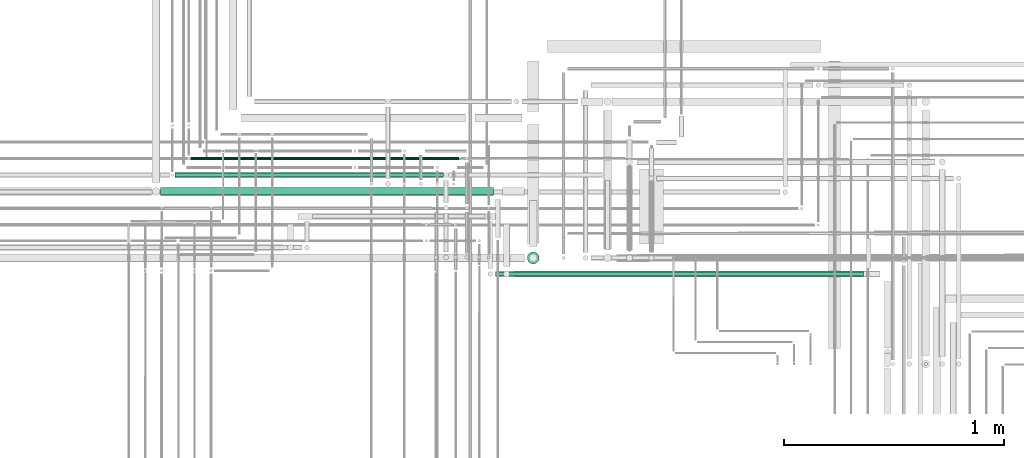
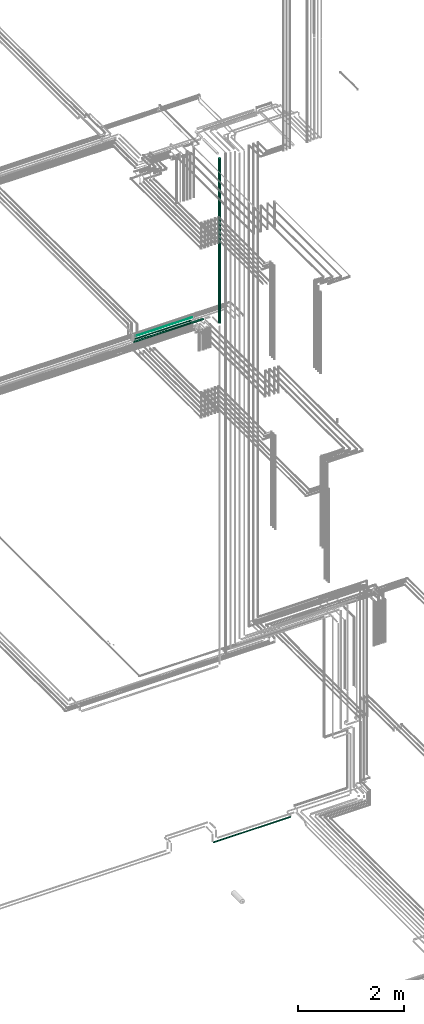
# One storey, part 83 of 331: 5 flow segments.
"""IFC2X3 building model written with IfcOpenShell, lengths in millimetres."""

from ifc_helpers import new_model, entity, si_unit, converted_unit, derived_unit, direction, frame, frame_2d, origin, origin_2d_with_axis, place, context, subcontext, project, spatial, circle, extrude, type_object, element, save


model = new_model("IFC2X3")

# Units and contexts
model_context = context("Model", 3, precision=0.01, world=origin(), true_north=direction((6.12303176911189e-17, 1.0)))
body_context = subcontext(model_context, "Body", "Model", "MODEL_VIEW")
ifc_project = project(units=[si_unit("LENGTHUNIT", "METRE", prefix="MILLI"), si_unit("AREAUNIT", "SQUARE_METRE"), si_unit("VOLUMEUNIT", "CUBIC_METRE"), converted_unit("PLANEANGLEUNIT", "DEGREE", entity("IfcRatioMeasure", 0.0174532925199433), si_unit("PLANEANGLEUNIT", "RADIAN"), dimensions=[0, 0, 0, 0, 0, 0, 0]), si_unit("MASSUNIT", "GRAM", prefix="KILO"), derived_unit("MASSDENSITYUNIT", [(si_unit("MASSUNIT", "GRAM", prefix="KILO"), 1), (si_unit("LENGTHUNIT", "METRE"), -3)]), derived_unit("MOMENTOFINERTIAUNIT", [(si_unit("LENGTHUNIT", "METRE"), 4)]), si_unit("TIMEUNIT", "SECOND"), si_unit("FREQUENCYUNIT", "HERTZ"), si_unit("THERMODYNAMICTEMPERATUREUNIT", "DEGREE_CELSIUS"), derived_unit("THERMALTRANSMITTANCEUNIT", [(si_unit("MASSUNIT", "GRAM", prefix="KILO"), 1), (si_unit("THERMODYNAMICTEMPERATUREUNIT", "KELVIN"), -1), (si_unit("TIMEUNIT", "SECOND"), -3)]), derived_unit("VOLUMETRICFLOWRATEUNIT", [(si_unit("LENGTHUNIT", "METRE"), 3), (si_unit("TIMEUNIT", "SECOND"), -1)]), derived_unit("MASSFLOWRATEUNIT", [(si_unit("MASSUNIT", "GRAM", prefix="KILO"), 1), (si_unit("TIMEUNIT", "SECOND"), -1)]), derived_unit("ROTATIONALFREQUENCYUNIT", [(si_unit("TIMEUNIT", "SECOND"), -1)]), si_unit("ELECTRICCURRENTUNIT", "AMPERE"), si_unit("ELECTRICVOLTAGEUNIT", "VOLT"), si_unit("POWERUNIT", "WATT"), si_unit("FORCEUNIT", "NEWTON", prefix="KILO"), si_unit("ILLUMINANCEUNIT", "LUX"), si_unit("LUMINOUSFLUXUNIT", "LUMEN"), si_unit("LUMINOUSINTENSITYUNIT", "CANDELA"), derived_unit("USERDEFINED", [(si_unit("MASSUNIT", "GRAM", prefix="KILO"), -1), (si_unit("LENGTHUNIT", "METRE"), -2), (si_unit("TIMEUNIT", "SECOND"), 3), (si_unit("LUMINOUSFLUXUNIT", "LUMEN"), 1)]), derived_unit("LINEARVELOCITYUNIT", [(si_unit("LENGTHUNIT", "METRE"), 1), (si_unit("TIMEUNIT", "SECOND"), -1)]), si_unit("PRESSUREUNIT", "PASCAL"), derived_unit("USERDEFINED", [(si_unit("LENGTHUNIT", "METRE"), -2), (si_unit("MASSUNIT", "GRAM", prefix="KILO"), 1), (si_unit("TIMEUNIT", "SECOND"), -2)]), derived_unit("LINEARFORCEUNIT", [(si_unit("MASSUNIT", "GRAM", prefix="KILO"), 1), (si_unit("LENGTHUNIT", "METRE"), 1), (si_unit("TIMEUNIT", "SECOND"), -2), (si_unit("LENGTHUNIT", "METRE"), -1)]), derived_unit("PLANARFORCEUNIT", [(si_unit("MASSUNIT", "GRAM", prefix="KILO"), 1), (si_unit("LENGTHUNIT", "METRE"), 1), (si_unit("TIMEUNIT", "SECOND"), -2), (si_unit("LENGTHUNIT", "METRE"), -2)])], contexts=[model_context])

# Site, building, storey
site_placement = place(None, frame((0.0, -0.00077364408347762, 0.0)))
site = spatial("IfcSite", under=ifc_project, at=site_placement, CompositionType="ELEMENT")
building_placement = place(site_placement, origin())
building = spatial("IfcBuilding", under=site, at=building_placement, CompositionType="ELEMENT")
storey_placement = place(building_placement, origin())
storey = spatial("IfcBuildingStorey", under=building, at=storey_placement, CompositionType="ELEMENT", Elevation=0.0)

# Flow segments
pipe_segment_type = type_object("IfcPipeSegmentType", PredefinedType="NOTDEFINED")
flow_segment_1_placement = place(storey_placement, frame((62152.1085312929, 8593.02529159146, 14542.4047277641)))
element("IfcFlowSegment", 1, at=flow_segment_1_placement, inside=storey, type_object=pipe_segment_type, context=body_context, shape_type="SweptSolid", body=[
    extrude(circle(Radius=6.0, at=frame_2d((-2.16573425859679e-12, -2.16573425859679e-12), x_axis=(1.0, 0.0))), frame((0.0, 7.59527223591778, 7.59527223591887), z_axis=(1.0, 0.0, 0.0), x_axis=(0.0, 1.0, 0.0)), (0.0, 0.0, 1.0), 1223.33548501375),
])
flow_segment_2_placement = place(storey_placement, frame((62082.1085312929, 8513.02529159144, 14537.4047277641)))
element("IfcFlowSegment", 2, at=flow_segment_2_placement, inside=storey, type_object=pipe_segment_type, context=body_context, shape_type="SweptSolid", body=[
    extrude(circle(Radius=11.0, at=origin_2d_with_axis()), frame((0.0, 12.5952722359156, 12.5952722359156), z_axis=(1.0, 0.0, 0.0), x_axis=(0.0, 1.0, 0.0)), (0.0, 0.0, 1.0), 1221.70253247952),
])
flow_segment_3_placement = place(storey_placement, frame((62016.1085312929, 8431.52529159143, 14530.904727764)))
element("IfcFlowSegment", 3, at=flow_segment_3_placement, inside=storey, type_object=pipe_segment_type, context=body_context, shape_type="SweptSolid", body=[
    extrude(circle(Radius=17.5, at=frame_2d((1.08286712929839e-12, 0.0), x_axis=(1.0, 0.0))), frame((0.0, 19.0952722359173, 19.0952722359163), z_axis=(1.0, 0.0, 0.0), x_axis=(0.0, 1.0, 0.0)), (0.0, 0.0, 1.0), 1514.68262091923),
])
flow_segment_4_placement = place(building_placement, frame((63684.0166110417, 8119.33499464522, 14580.0)))
element("IfcFlowSegment", 4, at=flow_segment_4_placement, inside=storey, type_object=pipe_segment_type, context=body_context, shape_type="SweptSolid", body=[
    extrude(circle(Radius=27.0, at=origin_2d_with_axis()), frame((28.5952722359184, 28.5952722359163, 0.0), z_axis=(0.0, 0.0, 1.0), x_axis=(-1.0, 0.0, 0.0)), (0.0, 0.0, 1.0), 3805.0),
])
flow_segment_5_placement = place(building_placement, frame((63540.9955203528, 8062.40472776409, 2687.40472776408)))
element("IfcFlowSegment", 5, at=flow_segment_5_placement, inside=storey, type_object=pipe_segment_type, context=body_context, shape_type="SweptSolid", body=[
    extrude(circle(Radius=11.0, at=frame_2d((1.08286712929839e-12, -5.41433564649196e-13), x_axis=(1.0, 0.0))), frame((0.0, 12.5952722359145, 12.5952722359166), z_axis=(1.0, 0.0, 0.0), x_axis=(0.0, 1.0, 0.0)), (0.0, 0.0, 1.0), 1675.20472745733),
])

save(model, "model.ifc")
